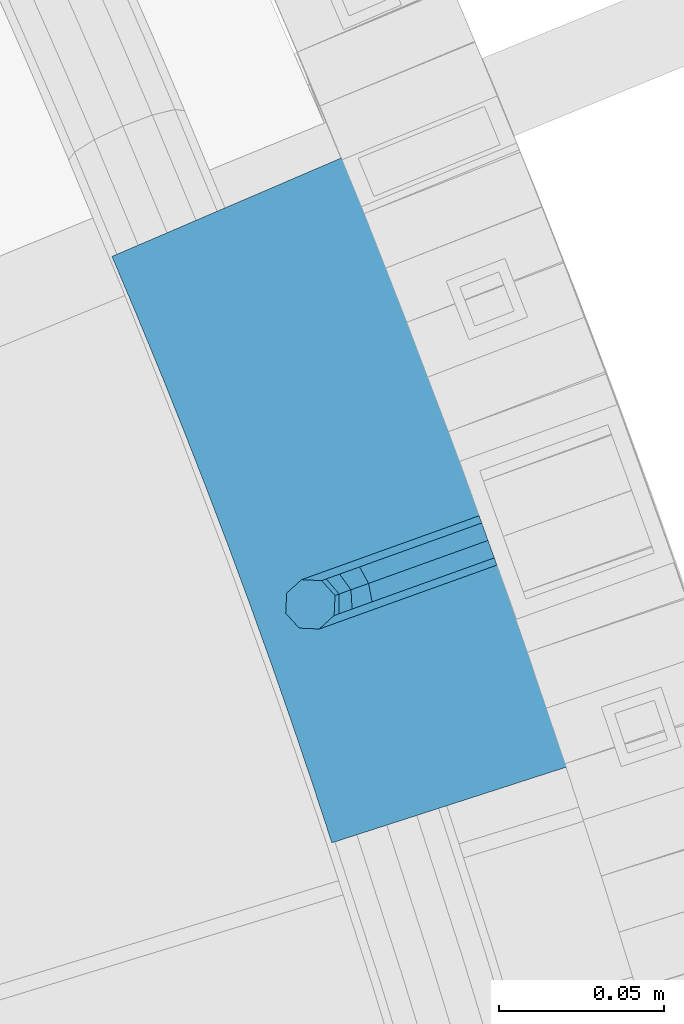
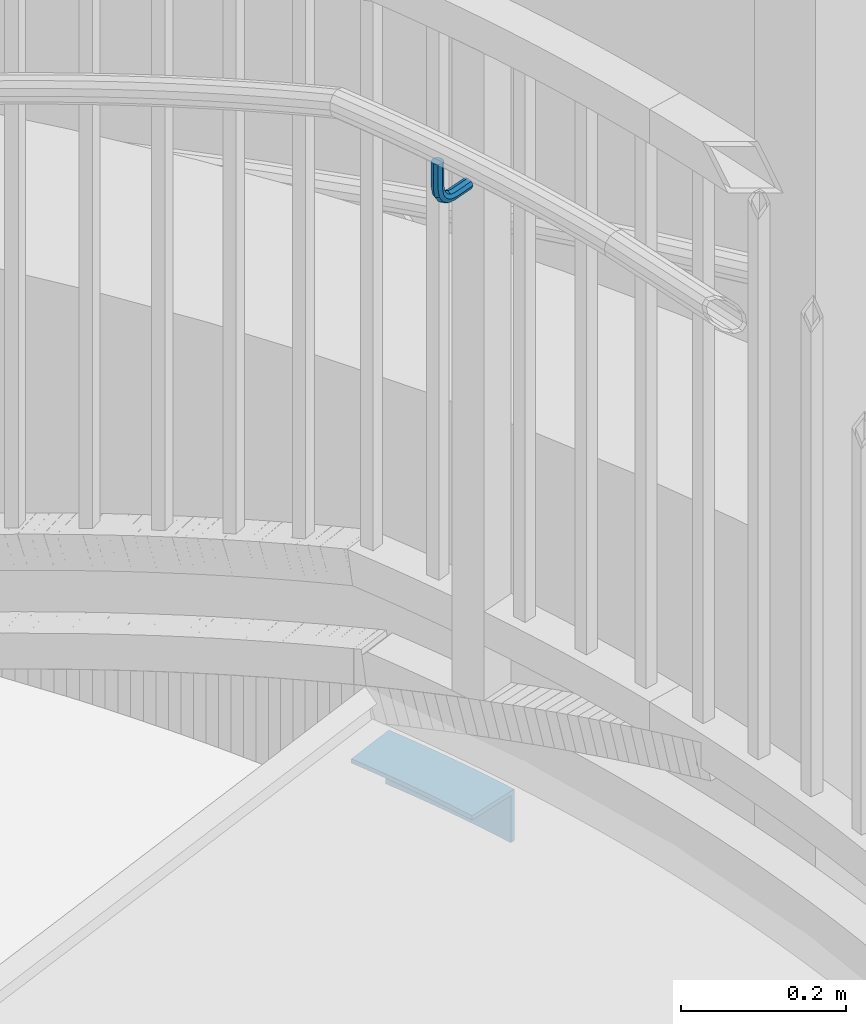
# One storey, part 508 of 975: 2 beams.
"""IFC2X3 building model written with IfcOpenShell, lengths in millimetres."""

from ifc_helpers import new_model, si_unit, frame, origin_with_axes, place, context, subcontext, project, spatial, faceted_brep, material, type_object, element, save


model = new_model("IFC2X3")

# Units and contexts
model_context = context("Model", 3, precision=1e-05, world=origin_with_axes())
body_context = subcontext(model_context, "Body", "Model", "MODEL_VIEW")
ifc_project = project(units=[si_unit("LENGTHUNIT", "METRE", prefix="MILLI"), si_unit("AREAUNIT", "SQUARE_METRE"), si_unit("VOLUMEUNIT", "CUBIC_METRE"), si_unit("MASSUNIT", "GRAM", prefix="KILO"), si_unit("TIMEUNIT", "SECOND"), si_unit("PLANEANGLEUNIT", "RADIAN"), si_unit("SOLIDANGLEUNIT", "STERADIAN"), si_unit("THERMODYNAMICTEMPERATUREUNIT", "DEGREE_CELSIUS"), si_unit("LUMINOUSINTENSITYUNIT", "LUMEN")], contexts=[model_context])

# Site, building, storey
site_placement = place(None, origin_with_axes())
site = spatial("IfcSite", under=ifc_project, at=site_placement, CompositionType="ELEMENT")
building_placement = place(site_placement, origin_with_axes())
building = spatial("IfcBuilding", under=site, at=building_placement, Name="Undefined", CompositionType="ELEMENT")
storey_placement = place(building_placement, origin_with_axes())
storey = spatial("IfcBuildingStorey", under=building, at=storey_placement, Name="Undefined", CompositionType="ELEMENT", Elevation=0.0)

# Beams
ifc_material = material(Name="STEEL/A36")
beam_type_1 = type_object("IfcBeamType", PredefinedType="NOTDEFINED")
beam_1_placement = place(storey_placement, frame((37410.7907150828, 4368.14914295234, 2946.40901031494), z_axis=(0.0, 0.0, 1.0), x_axis=(-0.940930943775437, -0.338598521919197, 0.0)))
element("IfcBeam", 1, at=beam_1_placement, inside=storey, type_object=beam_type_1, material=ifc_material, Name="BRACKET", context=body_context, shape_type="Brep", body=[
    faceted_brep([(-4.22995071858168e-07, -7.93750000000728, 0.0), (-2.99107341561466e-07, -5.61266007567065, -5.61266007566792), (31.7499842270954, -5.6126618385606, -5.6126600757234), (31.7499840980236, -7.93750176289177, -5.54791768081486e-11), (-1.09139364212751e-11, 1.81898940354586e-12, -7.9375), (31.7499845387247, -1.7628881323617e-06, -7.93750000005548), (2.99089151667431e-07, 5.61266007567428, -5.61266007566792), (31.7499848503612, 5.61265831278433, -5.6126600757234), (4.22980519942939e-07, 7.93750000001091, 0.0), (31.7499849794513, 7.93749823711914, -5.54791768081486e-11), (2.99089151667431e-07, 5.61266007567428, 5.61266007566792), (31.7499848503794, 5.61265831278433, 5.61266007561244), (-1.09139364212751e-11, 1.81898940354586e-12, 7.9375), (31.7499845387538, -1.7628881323617e-06, 7.93749999994452), (-2.99107341561466e-07, -5.61266007567065, 5.61266007566792), (31.7499842271172, -5.6126618385606, 5.61266007561244), (44.5076933192395, -2.47124626184814e-06, -5.39983394420233), (43.618015285665, -5.61266249752225, -3.25196192174644), (41.4701431341346, -7.93750230259684, 1.9334598451087), (39.322271240766, -5.61266225900181, 7.11888161196475), (38.432593830461, -2.1339365048334e-06, 9.26675363442064), (39.3222718640282, 5.61265789233948, 7.11888161196475), (41.4701440155623, 7.93749769741771, 1.9334598451087), (43.6180159089272, 5.61265765382268, -3.25196192174644), (53.6792468227941, 5.61265709518557, 3.47073764605557), (55.32315658683, -3.07176742353477e-06, 1.82682757038583), (49.7104969518768, 7.93749723988003, 7.43948764606012), (45.7417468228014, 5.61265753590487, 11.4082376460638), (44.0978364355033, -2.44848706643097e-06, 13.0521477217335), (45.7417461995356, -5.61266261544006, 11.4082376460638), (49.7104960704528, -7.93750276013816, 7.43948764606012), (53.6792461995283, -5.612663056163, 3.47073764605648), (60.4019463906188, 5.61265672191075, 13.5319685599115), (62.5498181014409, -3.47302193404175e-06, 12.6422908379673), (55.2165247528465, 7.93749693416248, 15.6798405823693), (50.0311028569122, 5.61265729774459, 17.8277126048279), (47.8832305228243, -2.65866765403189e-06, 18.7173903267721), (50.03110223365, -5.61266285360034, 17.8277126048279), (55.2165238714188, -7.93750306585207, 15.6798405823693), (60.4019457673567, -5.61266342943782, 13.5319685599115), (62.7626445446149, 5.61265659083438, 25.3999996184748), (65.0874841573168, -3.61392449121922e-06, 25.3999996184748), (57.1499845980288, 7.93749682680573, 25.3999996184748), (51.5373243932772, 5.61265721410746, 25.3999996184748), (49.2124841573132, -2.73247496807016e-06, 25.3999996184748), (51.5373237700151, -5.61266293723384, 25.3999996184748), (57.1499837166011, -7.93750317320519, 25.3999996184748), (62.7626439213527, -5.61266356051055, 25.3999996184748), (62.7626439213527, -5.61266356051055, 63.4909896850586), (57.1499837166011, -7.93750317320519, 63.4909896850586), (65.0874841573168, -3.61392449121922e-06, 63.4909896850586), (62.7626445446149, 5.61265659083438, 63.4909896850586), (57.1499845980288, 7.93749682680573, 63.4909896850586), (51.5373243932772, 5.61265721410746, 63.4909896850586), (49.2124841573132, -2.73247496807016e-06, 63.4909896850586), (51.5373237700151, -5.61266293723384, 63.4909896850586)], [[[0, 1, 2, 3]], [[1, 4, 5, 2]], [[4, 6, 7, 5]], [[6, 8, 9, 7]], [[8, 10, 11, 9]], [[10, 12, 13, 11]], [[12, 14, 15, 13]], [[14, 0, 3, 15]], [[14, 12, 10, 8, 6, 4, 1, 0]], [[2, 5, 16, 17]], [[3, 2, 17, 18]], [[15, 3, 18, 19]], [[13, 15, 19, 20]], [[11, 13, 20, 21]], [[9, 11, 21, 22]], [[7, 9, 22, 23]], [[5, 7, 23, 16]], [[23, 24, 25, 16]], [[22, 26, 24, 23]], [[21, 27, 26, 22]], [[20, 28, 27, 21]], [[19, 29, 28, 20]], [[18, 30, 29, 19]], [[17, 31, 30, 18]], [[16, 25, 31, 17]], [[24, 32, 33, 25]], [[26, 34, 32, 24]], [[27, 35, 34, 26]], [[28, 36, 35, 27]], [[29, 37, 36, 28]], [[30, 38, 37, 29]], [[31, 39, 38, 30]], [[25, 33, 39, 31]], [[32, 40, 41, 33]], [[34, 42, 40, 32]], [[35, 43, 42, 34]], [[36, 44, 43, 35]], [[37, 45, 44, 36]], [[38, 46, 45, 37]], [[39, 47, 46, 38]], [[33, 41, 47, 39]], [[46, 47, 48, 49]], [[47, 41, 50, 48]], [[41, 40, 51, 50]], [[40, 42, 52, 51]], [[42, 43, 53, 52]], [[43, 44, 54, 53]], [[44, 45, 55, 54]], [[45, 46, 49, 55]], [[50, 51, 52, 53, 54, 55, 49, 48]]]),
])
beam_type_2 = type_object("IfcBeamType", Name="L3X3X1/4", PredefinedType="NOTDEFINED")
beam_2_placement = place(storey_placement, frame((37331.9472157032, 4469.13901374294, 2044.7), z_axis=(-0.936297125860728, -0.351208900947769, 0.0), x_axis=(0.351208900947769, -0.936297125860728, 0.0)))
element("IfcBeam", 2, at=beam_2_placement, inside=storey, type_object=beam_type_2, material=ifc_material, Name="ANGLE", ObjectType="L3X3X1/4", context=body_context, shape_type="Brep", body=[
    faceted_brep([(1.77717605097678, 38.0999999999999, 38.0585292054384), (1.77717605097678, 31.75, 38.0585292054384), (20.7252114271232, 31.75, 37.2623236487925), (20.7252114271232, 38.0999999999999, 37.2623236487925), (-1.48098004247913, 31.75, -31.715441004555), (-1.48098004247913, -38.0999999999999, -31.715441004555), (18.1183459721651, -38.0999999999999, -32.5390141069583), (18.1183459721651, 31.75, -32.5390141069583), (-1.77717605097496, -38.0999999999999, -38.0585292054529), (-1.77717605097496, 38.0999999999999, -38.0585292054529), (17.8813582035345, 38.0999999999999, -38.8845902665853), (17.8813582035345, -38.0999999999999, -38.8845902665853), (39.6798520795146, 31.75, 36.6429807366221), (39.6798520795146, 38.0999999999999, 36.6429807366221), (37.7245043026669, -38.0999999999999, -33.179645360251), (37.7245043026669, 31.75, -33.179645360251), (37.5467454138652, 38.0999999999999, -39.5271568236203), (37.5467454138652, -38.0999999999999, -39.5271568236203), (58.6394471925214, 31.75, 36.2005544093408), (58.6394471925214, 38.0999999999999, 36.2005544093408), (57.3357873907935, -38.0999999999999, -33.6372789699526), (57.3357873907935, 31.75, -33.6372789699526), (57.217272863365, 38.0999999999999, -39.98617291353), (57.217272863365, -38.0999999999999, -39.98617291353), (77.6023455190116, 31.75, 35.9350831991615), (77.6023455190116, 38.0999999999999, 35.9350831991615), (76.9504872319903, -38.0999999999999, -33.9118750793932), (76.9504872319903, 31.75, -33.9118750793932), (76.8912273877158, 38.0999999999999, -40.2615985592638), (76.8912273877158, -38.0999999999999, -40.2615985592638), (96.5668955241654, 31.75, 35.8465902267635), (96.5668955241654, 38.0999999999999, 35.8465902267635), (96.5668955241144, -38.0999999999999, -34.0034097731914), (96.5668955241144, 31.75, -34.0034097731914), (96.5668955241072, 38.0999999999999, -40.3534097731826), (96.5668955241072, -38.0999999999999, -40.3534097731826), (115.531445529325, 31.75, 35.9350831992415), (115.531445529325, 38.0999999999999, 35.9350831992415), (116.183303816237, -38.0999999999999, -33.9118750793059), (116.183303816237, 31.75, -33.9118750793059), (116.242563660502, 38.0999999999999, -40.2615985591765), (116.242563660502, -38.0999999999999, -40.2615985591765), (134.494343855813, 31.75, 36.2005544095009), (134.494343855813, 38.0999999999999, 36.2005544095009), (135.798003657432, -38.0999999999999, -33.6372789697925), (135.798003657432, 31.75, -33.6372789697925), (135.916518184849, 38.0999999999999, -39.9861729133627), (135.916518184849, -38.0999999999999, -39.9861729133627), (153.45393896882, 31.75, 36.6429807368622), (153.45393896882, 38.0999999999999, 36.6429807368622), (155.409286745558, -38.0999999999999, -33.1796453600109), (155.409286745558, 31.75, -33.1796453600109), (155.587045634355, 38.0999999999999, -39.5271568233657), (155.587045634355, -38.0999999999999, -39.5271568233657), (172.408579621215, 31.75, 37.2623236491054), (172.408579621215, 38.0999999999999, 37.2623236491054), (175.015445076062, -38.0999999999999, -32.5390141066382), (175.015445076062, 31.75, -32.5390141066382), (175.252432844683, 38.0999999999999, -38.8845902662506), (175.252432844683, -38.0999999999999, -38.8845902662506), (191.356614997363, 38.0999999999999, 38.0585292058313), (194.910967099195, 38.0999999999999, -38.0585292050382), (191.356614997363, 31.75, 38.0585292058313), (194.614771090708, 31.75, -31.715441004133), (194.614771090708, -38.0999999999999, -31.715441004133), (194.910967099195, -38.0999999999999, -38.0585292050382)], [[[0, 1, 2, 3]], [[4, 5, 6, 7]], [[8, 9, 10, 11]], [[8, 5, 4, 1, 0, 9]], [[3, 2, 12, 13]], [[7, 6, 14, 15]], [[11, 10, 16, 17]], [[13, 12, 18, 19]], [[15, 14, 20, 21]], [[17, 16, 22, 23]], [[19, 18, 24, 25]], [[21, 20, 26, 27]], [[23, 22, 28, 29]], [[25, 24, 30, 31]], [[27, 26, 32, 33]], [[29, 28, 34, 35]], [[31, 30, 36, 37]], [[33, 32, 38, 39]], [[35, 34, 40, 41]], [[37, 36, 42, 43]], [[39, 38, 44, 45]], [[41, 40, 46, 47]], [[43, 42, 48, 49]], [[45, 44, 50, 51]], [[47, 46, 52, 53]], [[49, 48, 54, 55]], [[51, 50, 56, 57]], [[53, 52, 58, 59]], [[58, 52, 46, 40, 34, 28, 22, 16, 10, 9, 0, 3, 13, 19, 25, 31, 37, 43, 49, 55, 60, 61]], [[55, 54, 62, 60]], [[54, 48, 42, 36, 30, 24, 18, 12, 2, 1, 4, 7, 15, 21, 27, 33, 39, 45, 51, 57, 63, 62]], [[57, 56, 64, 63]], [[56, 50, 44, 38, 32, 26, 20, 14, 6, 5, 8, 11, 17, 23, 29, 35, 41, 47, 53, 59, 65, 64]], [[59, 58, 61, 65]], [[62, 63, 64, 65, 61, 60]]]),
])

save(model, "model.ifc")
